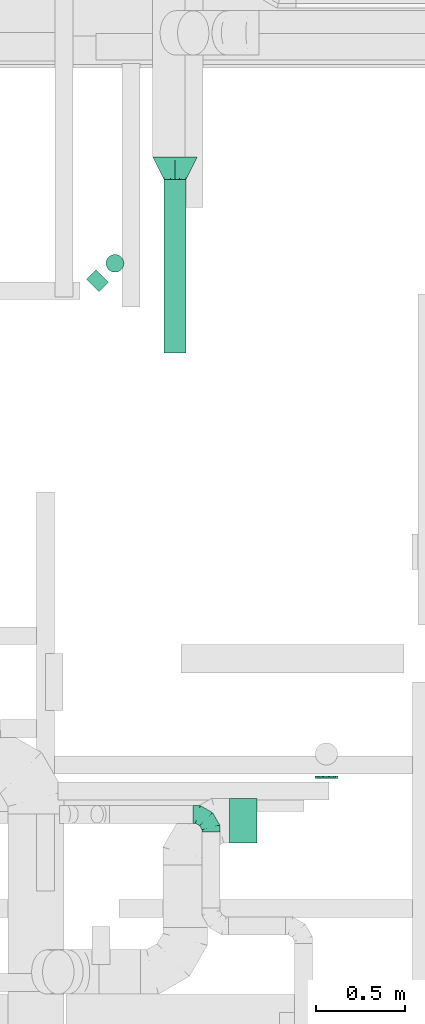
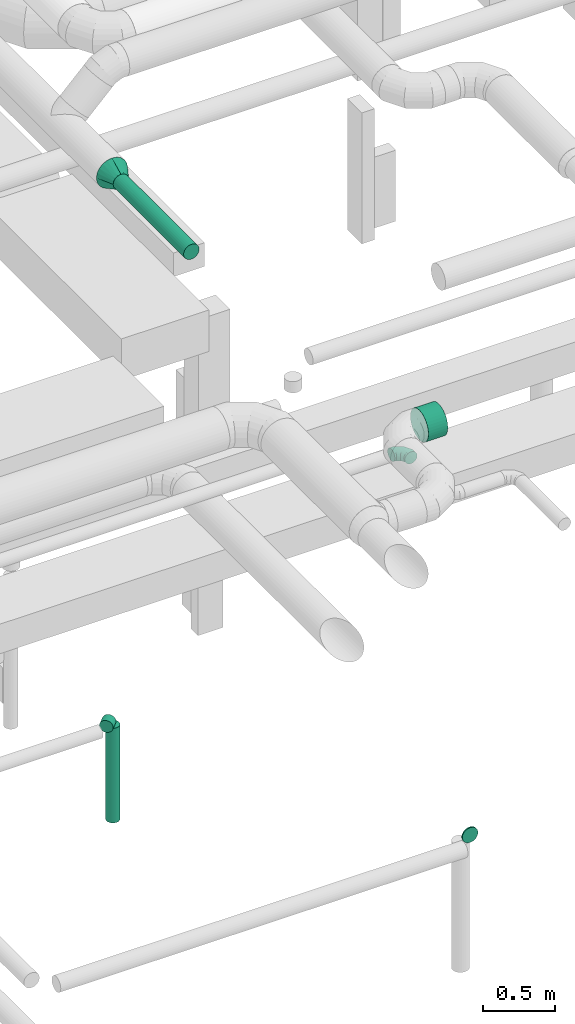
# One storey, part 127 of 337: 5 flow segments, 2 flow fittings.
"""IFC2X3 building model written with IfcOpenShell, lengths in millimetres."""

import ifcopenshell
import ifcopenshell.guid

model = None  # the IFC model being written
_history = None  # IfcOwnerHistory: only IFC2X3 demands one
_inside = {}  # id of a spatial element -> (the spatial element, [elements in it])
_under = {}  # id of a project, library or spatial element -> (it, [spatial elements below it])
_declared = {}  # id of a project -> (the project, [libraries it declares])
_typed = {}  # id of a type object -> (the type object, [elements of that type])
_made_of = {}  # id of a material, layer set ... -> (it, [elements and type objects made of it])


def new_model(schema):
    """Start an empty IFC model of exactly this schema.

    Asked for "IFC4X3", IfcOpenShell would pick the latest addendum, in which some entities
    have other attributes; the version numbers below select the first issue.
    IFC2X3 requires an IfcOwnerHistory on every rooted entity: one is made here for all.
    """
    global model, _history
    if schema == "IFC4X3":
        model = ifcopenshell.file(schema_version=(4, 3, 0, 0))
    else:
        model = ifcopenshell.file(schema=schema)
    _inside.clear()
    _under.clear()
    _declared.clear()
    _typed.clear()
    _made_of.clear()
    _history = None
    if model.schema == "IFC2X3":
        org = make("IfcOrganization", Name="unknown")
        user = make(
            "IfcPersonAndOrganization",
            ThePerson=make("IfcPerson", FamilyName="unknown"),
            TheOrganization=org,
        )
        app = make(
            "IfcApplication",
            ApplicationDeveloper=org,
            Version="unknown",
            ApplicationFullName="unknown",
            ApplicationIdentifier="unknown",
        )
        _history = make(
            "IfcOwnerHistory",
            OwningUser=user,
            OwningApplication=app,
            ChangeAction="ADDED",
            CreationDate=0,
        )
    return model


def make(cls, **values):
    """One entity of the class cls with the attributes given. An attribute that is None is left unset."""
    return model.create_entity(
        cls, **{name: value for name, value in values.items() if value is not None}
    )


def entity(cls, *values):
    """Any entity or typed value of the class cls, its attributes in the order of the schema. None: left unset."""
    e = model.create_entity(cls)
    for i, value in enumerate(values):
        if value is not None:
            e[i] = value
    return e


def rooted(cls, **values):
    """An entity with a GlobalId (a new one), such as an element, a storey or a relation."""
    return make(cls, GlobalId=ifcopenshell.guid.new(), OwnerHistory=_history, **values)


def si_unit(unit_type, name, prefix=None):
    """IfcSIUnit, for example si_unit("LENGTHUNIT", "METRE", prefix="MILLI")."""
    return make("IfcSIUnit", UnitType=unit_type, Prefix=prefix, Name=name)


def converted_unit(unit_type, name, factor, base, dimensions=None, offset=None):
    """IfcConversionBasedUnit, such as the inch: factor (a typed value) times the base unit."""
    return make(
        "IfcConversionBasedUnit"
        if offset is None
        else "IfcConversionBasedUnitWithOffset",
        ConversionOffset=offset,
        Dimensions=None
        if dimensions is None
        else entity("IfcDimensionalExponents", *dimensions),
        UnitType=unit_type,
        Name=name,
        ConversionFactor=make(
            "IfcMeasureWithUnit", ValueComponent=factor, UnitComponent=base
        ),
    )


def derived_unit(unit_type, elements):
    """IfcDerivedUnit: a product of units, each with its exponent."""
    return make(
        "IfcDerivedUnit",
        Elements=[
            make("IfcDerivedUnitElement", Unit=unit, Exponent=power)
            for unit, power in elements
        ],
        UnitType=unit_type,
    )


def assignment(units):
    """IfcUnitAssignment: the units of a project."""
    return None if units is None else make("IfcUnitAssignment", Units=units)


def point(xyz):
    """IfcCartesianPoint."""
    return None if xyz is None else make("IfcCartesianPoint", Coordinates=xyz)


def direction(xyz):
    """IfcDirection."""
    return None if xyz is None else make("IfcDirection", DirectionRatios=xyz)


def frame(location, z_axis=None, x_axis=None):
    """IfcAxis2Placement3D, a coordinate frame: its origin and axes. An axis left out is left unset."""
    return make(
        "IfcAxis2Placement3D",
        Location=point(location),
        Axis=direction(z_axis),
        RefDirection=direction(x_axis),
    )


def frame_2d(location, x_axis=None):
    """IfcAxis2Placement2D, a coordinate frame in the plane: its origin and x axis."""
    return make(
        "IfcAxis2Placement2D", Location=point(location), RefDirection=direction(x_axis)
    )


def origin():
    """The frame at (0, 0, 0) with its axes left unset."""
    return frame((0.0, 0.0, 0.0))


def origin_2d_with_axis():
    """The frame at (0, 0) in the plane with the x axis (1, 0) written out."""
    return frame_2d((0.0, 0.0), x_axis=(1.0, 0.0))


def place(relative_to, where):
    """IfcLocalPlacement: puts the frame where relative to a parent placement (None: the world)."""
    return make(
        "IfcLocalPlacement", PlacementRelTo=relative_to, RelativePlacement=where
    )


def context(
    kind, dimensions, precision=None, world=None, true_north=None, identifier=None
):
    """IfcGeometricRepresentationContext, for example the 3D "Model" context."""
    return make(
        "IfcGeometricRepresentationContext",
        ContextIdentifier=identifier,
        ContextType=kind,
        CoordinateSpaceDimension=dimensions,
        Precision=precision,
        WorldCoordinateSystem=world,
        TrueNorth=true_north,
    )


def subcontext(parent, identifier, kind, view, scale=None):
    """IfcGeometricRepresentationSubContext, for example "Body" below "Model"."""
    return make(
        "IfcGeometricRepresentationSubContext",
        ContextIdentifier=identifier,
        ContextType=kind,
        ParentContext=parent,
        TargetScale=scale,
        TargetView=view,
    )


def project(units=None, contexts=None):
    """IfcProject with its units and contexts."""
    return rooted(
        "IfcProject",
        Name="project",
        RepresentationContexts=contexts,
        UnitsInContext=assignment(units),
    )


def spatial(cls, under=None, at=None, **own):
    """A site, building, storey or space (cls), placed at a placement, below another one or the project."""
    s = rooted(cls, ObjectPlacement=at, **own)
    if under is not None:
        _under.setdefault(under.id(), (under, []))[1].append(s)
    return s


def profile(cls, at=None, kind="AREA", **sizes):
    """A parametric profile (cls). Its sizes go by their IFC names, for example OverallWidth=200.0."""
    return make(cls, ProfileType=kind, Position=at, **sizes)


def circle(**sizes):
    """IfcCircleProfileDef."""
    return profile("IfcCircleProfileDef", **sizes)


def extrude(swept, where, along, depth):
    """IfcExtrudedAreaSolid: the profile swept, set in the frame where, extruded along a direction by depth."""
    return make(
        "IfcExtrudedAreaSolid",
        SweptArea=swept,
        Position=where,
        ExtrudedDirection=direction(along),
        Depth=depth,
    )


def faces_of(points, faces, orient=None, outer=None):
    """IfcFace entities. A face is a list of loops; a loop is a list of indices into points, from 0.

    orient and outer hold one flag for each loop. By default every Orientation is true, the
    first loop of a face is its IfcFaceOuterBound and the others are IfcFaceBound.
    """
    made = []
    for i, loops in enumerate(faces):
        bounds = []
        for j, loop in enumerate(loops):
            is_outer = j == 0 if outer is None else outer[i][j]
            bounds.append(
                make(
                    "IfcFaceOuterBound" if is_outer else "IfcFaceBound",
                    Bound=make("IfcPolyLoop", Polygon=[points[k] for k in loop]),
                    Orientation=True if orient is None else orient[i][j],
                )
            )
        made.append(make("IfcFace", Bounds=bounds))
    return made


def faceted_brep(points, faces, orient=None, outer=None, voids=None):
    """IfcFacetedBrep: a solid bounded by flat faces; with voids (closed shells), ...WithVoids."""
    shared = [point(p) for p in points]
    hull = make("IfcClosedShell", CfsFaces=faces_of(shared, faces, orient, outer))
    if voids is None:
        return make("IfcFacetedBrep", Outer=hull)
    return make(
        "IfcFacetedBrepWithVoids",
        Outer=hull,
        Voids=[
            make(cls, CfsFaces=faces_of(shared, fs, o, b)) for cls, fs, o, b in voids
        ],
    )


def shape(context_of_items, identifier, shape_type, items):
    """IfcShapeRepresentation: the items that make up one representation, for example the "Body"."""
    return make(
        "IfcShapeRepresentation",
        ContextOfItems=context_of_items,
        RepresentationIdentifier=identifier,
        RepresentationType=shape_type,
        Items=items,
    )


def source(mapping_origin, context_of_items, identifier, shape_type, items):
    """IfcRepresentationMap: a shape defined once, which mapped items show again and again."""
    return make(
        "IfcRepresentationMap",
        MappingOrigin=mapping_origin,
        MappedRepresentation=shape(context_of_items, identifier, shape_type, items),
    )


def transform(
    local_origin,
    x_axis=None,
    y_axis=None,
    z_axis=None,
    scale=None,
    scale2=None,
    scale3=None,
    uniform=True,
):
    """IfcCartesianTransformationOperator3D, or its non-uniform kind. x_axis, y_axis, z_axis: its Axis1, 2, 3."""
    if uniform:
        return make(
            "IfcCartesianTransformationOperator3D",
            Axis1=direction(x_axis),
            Axis2=direction(y_axis),
            LocalOrigin=point(local_origin),
            Scale=scale,
            Axis3=direction(z_axis),
        )
    return make(
        "IfcCartesianTransformationOperator3DnonUniform",
        Axis1=direction(x_axis),
        Axis2=direction(y_axis),
        LocalOrigin=point(local_origin),
        Scale=scale,
        Axis3=direction(z_axis),
        Scale2=scale2,
        Scale3=scale3,
    )


def mapped(mapping_source, mapping_target):
    """IfcMappedItem: shows the shape of a source again, moved by a transform."""
    return make(
        "IfcMappedItem", MappingSource=mapping_source, MappingTarget=mapping_target
    )


def material(Name=None, Category=None):
    """IfcMaterial."""
    return make("IfcMaterial", Name=Name, Category=Category)


def made_of(thing, what):
    """Note that an element or type object is made of a material, layer set ...; save() writes the relation."""
    if what is not None:
        _made_of.setdefault(what.id(), (what, []))[1].append(thing)
    return thing


def type_object(cls, material=None, **own):
    """A type object (cls), such as IfcWallType, which elements share."""
    return made_of(rooted(cls, **own), material)


def type_shapes(of_type, sources):
    """Give a type object the sources (RepresentationMaps) that its elements show as mapped items."""
    of_type.RepresentationMaps = sources


def element(
    cls,
    number,
    at=None,
    inside=None,
    cuts=None,
    type_object=None,
    material=None,
    context=None,
    identifier="Body",
    shape_type=None,
    held_by="IfcProductDefinitionShape",
    body=None,
    shapes=None,
    **own,
):
    """One element of the class cls, such as IfcWall. Its Tag is "e" and its number.

    at: its placement. inside: the storey or other place that contains it. cuts: it is an
    opening in that element (IfcRelVoidsElement). A single representation is given by context,
    identifier, shape_type and body (its items); several are given by shapes. held_by: the class
    of the entity that holds the representations. save() writes the other relations.
    """
    e = rooted(cls, Tag="e%d" % number, ObjectPlacement=at, **own)
    if body is not None:
        shapes = [shape(context, identifier, shape_type, body)]
    if shapes is not None:
        e.Representation = make(held_by, Representations=shapes)
    if inside is not None:
        _inside.setdefault(inside.id(), (inside, []))[1].append(e)
    if cuts is not None:
        rooted(
            "IfcRelVoidsElement", RelatingBuildingElement=cuts, RelatedOpeningElement=e
        )
    if type_object is not None:
        _typed.setdefault(type_object.id(), (type_object, []))[1].append(e)
    return made_of(e, material)


def aggregate(whole, parts):
    """IfcRelAggregates: a whole, such as a stair, and the parts it consists of."""
    return rooted("IfcRelAggregates", RelatingObject=whole, RelatedObjects=parts)


def save(model, path):
    """Write the relations noted so far, then the file.

    IfcRelAggregates (storeys below a building ...), IfcRelContainedInSpatialStructure (elements
    in a storey), IfcRelDefinesByType, IfcRelAssociatesMaterial and IfcRelDeclares: one each for
    every whole, place, type object, material and project.
    """
    for whole, parts in _under.values():
        aggregate(whole, parts)
    for where, things in _inside.values():
        rooted(
            "IfcRelContainedInSpatialStructure",
            RelatedElements=things,
            RelatingStructure=where,
        )
    for kind, things in _typed.values():
        rooted("IfcRelDefinesByType", RelatedObjects=things, RelatingType=kind)
    for what, things in _made_of.values():
        rooted("IfcRelAssociatesMaterial", RelatedObjects=things, RelatingMaterial=what)
    for by, libraries in _declared.values():
        rooted("IfcRelDeclares", RelatingContext=by, RelatedDefinitions=libraries)
    model.write(path)


model = new_model("IFC2X3")

# Units and contexts
model_context = context("Model", 3, precision=0.01, world=origin(), true_north=direction((6.12303176911189e-17, 1.0)))
body_context = subcontext(model_context, "Body", "Model", "MODEL_VIEW")
ifc_project = project(units=[si_unit("LENGTHUNIT", "METRE", prefix="MILLI"), si_unit("AREAUNIT", "SQUARE_METRE"), si_unit("VOLUMEUNIT", "CUBIC_METRE"), converted_unit("PLANEANGLEUNIT", "DEGREE", entity("IfcRatioMeasure", 0.0174532925199433), si_unit("PLANEANGLEUNIT", "RADIAN"), dimensions=[0, 0, 0, 0, 0, 0, 0]), si_unit("MASSUNIT", "GRAM", prefix="KILO"), derived_unit("MASSDENSITYUNIT", [(si_unit("MASSUNIT", "GRAM", prefix="KILO"), 1), (si_unit("LENGTHUNIT", "METRE"), -3)]), derived_unit("MOMENTOFINERTIAUNIT", [(si_unit("LENGTHUNIT", "METRE"), 4)]), si_unit("TIMEUNIT", "SECOND"), si_unit("FREQUENCYUNIT", "HERTZ"), si_unit("THERMODYNAMICTEMPERATUREUNIT", "DEGREE_CELSIUS"), derived_unit("THERMALTRANSMITTANCEUNIT", [(si_unit("MASSUNIT", "GRAM", prefix="KILO"), 1), (si_unit("THERMODYNAMICTEMPERATUREUNIT", "KELVIN"), -1), (si_unit("TIMEUNIT", "SECOND"), -3)]), derived_unit("VOLUMETRICFLOWRATEUNIT", [(si_unit("LENGTHUNIT", "METRE"), 3), (si_unit("TIMEUNIT", "SECOND"), -1)]), derived_unit("MASSFLOWRATEUNIT", [(si_unit("MASSUNIT", "GRAM", prefix="KILO"), 1), (si_unit("TIMEUNIT", "SECOND"), -1)]), derived_unit("ROTATIONALFREQUENCYUNIT", [(si_unit("TIMEUNIT", "SECOND"), -1)]), si_unit("ELECTRICCURRENTUNIT", "AMPERE"), si_unit("ELECTRICVOLTAGEUNIT", "VOLT"), si_unit("POWERUNIT", "WATT"), si_unit("FORCEUNIT", "NEWTON", prefix="KILO"), si_unit("ILLUMINANCEUNIT", "LUX"), si_unit("LUMINOUSFLUXUNIT", "LUMEN"), si_unit("LUMINOUSINTENSITYUNIT", "CANDELA"), derived_unit("USERDEFINED", [(si_unit("MASSUNIT", "GRAM", prefix="KILO"), -1), (si_unit("LENGTHUNIT", "METRE"), -2), (si_unit("TIMEUNIT", "SECOND"), 3), (si_unit("LUMINOUSFLUXUNIT", "LUMEN"), 1)]), derived_unit("LINEARVELOCITYUNIT", [(si_unit("LENGTHUNIT", "METRE"), 1), (si_unit("TIMEUNIT", "SECOND"), -1)]), si_unit("PRESSUREUNIT", "PASCAL"), derived_unit("USERDEFINED", [(si_unit("LENGTHUNIT", "METRE"), -2), (si_unit("MASSUNIT", "GRAM", prefix="KILO"), 1), (si_unit("TIMEUNIT", "SECOND"), -2)]), derived_unit("LINEARFORCEUNIT", [(si_unit("MASSUNIT", "GRAM", prefix="KILO"), 1), (si_unit("LENGTHUNIT", "METRE"), 1), (si_unit("TIMEUNIT", "SECOND"), -2), (si_unit("LENGTHUNIT", "METRE"), -1)]), derived_unit("PLANARFORCEUNIT", [(si_unit("MASSUNIT", "GRAM", prefix="KILO"), 1), (si_unit("LENGTHUNIT", "METRE"), 1), (si_unit("TIMEUNIT", "SECOND"), -2), (si_unit("LENGTHUNIT", "METRE"), -2)])], contexts=[model_context])

# Site, building, storey
site_placement = place(None, origin())
site = spatial("IfcSite", under=ifc_project, at=site_placement, CompositionType="ELEMENT")
building_placement = place(site_placement, origin())
building = spatial("IfcBuilding", under=site, at=building_placement, CompositionType="ELEMENT")
storey_placement = place(building_placement, origin())
storey = spatial("IfcBuildingStorey", under=building, at=storey_placement, CompositionType="ELEMENT", Elevation=0.0)

# Flow segments
duct_segment_type = type_object("IfcDuctSegmentType", PredefinedType="NOTDEFINED")
flow_segment_1_placement = place(storey_placement, frame((37100.2, 4113.76, -664.1)))
element("IfcFlowSegment", 1, at=flow_segment_1_placement, inside=storey, type_object=duct_segment_type, context=body_context, shape_type="SweptSolid", body=[
    extrude(circle(Radius=62.5, at=origin_2d_with_axis()), frame((64.1, 0.0, 64.1), z_axis=(0.0, 1.0, 0.0), x_axis=(1.0, 0.0, 0.0)), (0.0, 0.0, 1.0), 9.92661999999447),
])
flow_segment_2_placement = place(storey_placement, frame((35815.06, 6841.85, -951.6)))
element("IfcFlowSegment", 2, at=flow_segment_2_placement, inside=storey, type_object=duct_segment_type, context=body_context, shape_type="SweptSolid", body=[
    extrude(circle(Radius=50.0, at=origin_2d_with_axis()), frame((36.95, 36.95, 51.6), z_axis=(0.707106781186548, 0.707106781186548, 0.0), x_axis=(0.707106781186548, -0.707106781186548, 0.0)), (0.0, 0.0, 1.0), 76.2779207257766),
])
flow_segment_3_placement = place(storey_placement, frame((35925.07, 6951.85, -1800.0)))
element("IfcFlowSegment", 3, at=flow_segment_3_placement, inside=storey, type_object=duct_segment_type, context=body_context, shape_type="SweptSolid", body=[
    extrude(circle(Radius=50.0, at=origin_2d_with_axis()), frame((51.6, 51.6, 0.0), z_axis=(0.0, 0.0, 1.0), x_axis=(-0.707106781186549, -0.707106781186546, 0.0)), (0.0, 0.0, 1.0), 800.000000000009),
])
flow_segment_4_placement = place(storey_placement, frame((36620.66, 3748.01, 3073.4)))
element("IfcFlowSegment", 4, at=flow_segment_4_placement, inside=storey, type_object=duct_segment_type, context=body_context, shape_type="SweptSolid", body=[
    extrude(circle(Radius=125.0, at=origin_2d_with_axis()), frame((0.0, 126.6, 126.6), z_axis=(1.0, 0.0, 0.0), x_axis=(0.0, -1.0, 0.0)), (0.0, 0.0, 1.0), 154.999999999999),
])
flow_segment_5_placement = place(storey_placement, frame((36249.81, 6500.0, 3115.9)))
element("IfcFlowSegment", 5, at=flow_segment_5_placement, inside=storey, type_object=duct_segment_type, context=body_context, shape_type="SweptSolid", body=[
    extrude(circle(Radius=62.5, at=origin_2d_with_axis()), frame((64.1, 0.0, 64.1), z_axis=(0.0, 1.0, 0.0), x_axis=(-1.0, 0.0, 0.0)), (0.0, 0.0, 1.0), 974.999999999985),
])

# Flow fittings
ifc_material = material()
duct_fitting_type_1 = type_object("IfcDuctFittingType", PredefinedType="NOTDEFINED", material=ifc_material)
shared_shape_1 = source(origin(), body_context, "Body", "Brep", [
    faceted_brep([(-100.0, 0.0, -50.0), (-100.0, -12.94, -48.3), (-100.0, -25.0, -43.3), (-100.0, -35.36, -35.36), (-100.0, -43.3, -25.0), (-100.0, -48.3, -12.94), (-100.0, -50.0, 0.0), (-100.0, -48.3, 12.94), (-100.0, -43.3, 25.0), (-100.0, -35.36, 35.36), (-100.0, -25.0, 43.3), (-100.0, -12.94, 48.3), (-100.0, 0.0, 50.0), (-100.0, 12.94, 48.3), (-100.0, 25.0, 43.3), (-100.0, 35.36, 35.36), (-100.0, 43.3, 25.0), (-100.0, 48.3, 12.94), (-100.0, 50.0, 0.0), (-100.0, 48.3, -12.94), (-100.0, 43.3, -25.0), (-100.0, 35.36, -35.36), (-100.0, 25.0, -43.3), (-100.0, 12.94, -48.3), (-76.67, 12.94, 48.3), (-79.9, 25.0, 43.3), (-73.21, 0.0, 50.0), (-82.68, 35.36, 35.36), (-86.15, 48.3, 12.94), (-86.6, 50.0, 0.0), (-84.81, 43.3, 25.0), (-84.81, 43.3, -25.0), (-82.68, 35.36, -35.36), (-86.15, 48.3, -12.94), (-76.67, 12.94, -48.3), (-73.21, 0.0, -50.0), (-79.9, 25.0, -43.3), (-69.74, -12.94, -48.3), (-66.51, -25.0, -43.3), (-63.73, -35.36, -35.36), (-61.6, -43.3, -25.0), (-60.26, -48.3, -12.94), (-59.81, -50.0, 0.0), (-60.26, -48.3, 12.94), (-61.6, -43.3, 25.0), (-63.73, -35.36, 35.36), (-66.51, -25.0, 43.3), (-69.74, -12.94, 48.3), (-36.27, 36.27, 48.3), (-45.1, 45.1, 43.3), (-26.79, 26.79, 50.0), (-52.68, 52.68, 35.36), (-58.49, 58.49, 25.0), (-62.15, 62.15, 12.94), (-63.4, 63.4, 0.0), (-62.15, 62.15, -12.94), (-58.49, 58.49, -25.0), (-52.68, 52.68, -35.36), (-36.27, 36.27, -48.3), (-26.79, 26.79, -50.0), (-45.1, 45.1, -43.3), (-17.32, 17.32, -48.3), (-8.49, 8.49, -43.3), (-0.91, 0.91, -35.36), (4.9, -4.9, -25.0), (8.56, -8.56, -12.94), (9.81, -9.81, 0.0), (8.56, -8.56, 12.94), (4.9, -4.9, 25.0), (-0.91, 0.91, 35.36), (-8.49, 8.49, 43.3), (-17.32, 17.32, 48.3), (-12.94, 76.67, 48.3), (-25.0, 79.9, 43.3), (0.0, 73.21, 50.0), (-35.36, 82.68, 35.36), (-43.3, 84.81, 25.0), (-48.3, 86.15, 12.94), (-50.0, 86.6, 0.0), (-48.3, 86.15, -12.94), (-43.3, 84.81, -25.0), (-35.36, 82.68, -35.36), (-12.94, 76.67, -48.3), (0.0, 73.21, -50.0), (-25.0, 79.9, -43.3), (12.94, 69.74, -48.3), (25.0, 66.51, -43.3), (35.36, 63.73, -35.36), (43.3, 61.6, -25.0), (48.3, 60.26, -12.94), (50.0, 59.81, 0.0), (48.3, 60.26, 12.94), (43.3, 61.6, 25.0), (35.36, 63.73, 35.36), (25.0, 66.51, 43.3), (12.94, 69.74, 48.3), (-12.94, 100.0, -48.3), (-25.0, 100.0, -43.3), (-35.36, 100.0, -35.36), (-43.3, 100.0, -25.0), (-48.3, 100.0, -12.94), (-50.0, 100.0, 0.0), (-48.3, 100.0, 12.94), (-43.3, 100.0, 25.0), (-35.36, 100.0, 35.36), (-25.0, 100.0, 43.3), (-12.94, 100.0, 48.3), (0.0, 100.0, 50.0), (12.94, 100.0, 48.3), (25.0, 100.0, 43.3), (35.36, 100.0, 35.36), (43.3, 100.0, 25.0), (48.3, 100.0, 12.94), (50.0, 100.0, 0.0), (48.3, 100.0, -12.94), (43.3, 100.0, -25.0), (35.36, 100.0, -35.36), (25.0, 100.0, -43.3), (12.94, 100.0, -48.3), (0.0, 100.0, -50.0)], [[[0, 1, 2, 3, 4, 5, 6, 7, 8, 9, 10, 11, 12, 13, 14, 15, 16, 17, 18, 19, 20, 21, 22, 23]], [[24, 25, 14, 13]], [[26, 24, 13, 12]], [[14, 25, 27, 15]], [[28, 29, 18, 17]], [[30, 28, 17, 16]], [[15, 27, 30, 16]], [[20, 31, 32, 21]], [[33, 31, 20, 19]], [[18, 29, 33, 19]], [[34, 35, 0, 23]], [[36, 34, 23, 22]], [[32, 36, 22, 21]], [[2, 1, 37, 38]], [[3, 2, 38, 39]], [[0, 35, 37, 1]], [[5, 4, 40, 41]], [[6, 5, 41, 42]], [[3, 39, 40, 4]], [[6, 42, 43, 7]], [[7, 43, 44, 8]], [[8, 44, 45, 9]], [[10, 46, 47, 11]], [[11, 47, 26, 12]], [[10, 9, 45, 46]], [[48, 49, 25, 24]], [[50, 48, 24, 26]], [[27, 25, 49, 51]], [[52, 53, 28, 30]], [[51, 52, 30, 27]], [[29, 28, 53, 54]], [[55, 56, 31, 33]], [[54, 55, 33, 29]], [[57, 32, 31, 56]], [[58, 59, 35, 34]], [[60, 58, 34, 36]], [[57, 60, 36, 32]], [[37, 35, 59, 61]], [[38, 37, 61, 62]], [[39, 38, 62, 63]], [[41, 40, 64, 65]], [[42, 41, 65, 66]], [[63, 64, 40, 39]], [[43, 42, 66, 67]], [[44, 43, 67, 68]], [[68, 69, 45, 44]], [[46, 45, 69, 70]], [[47, 46, 70, 71]], [[26, 47, 71, 50]], [[72, 73, 49, 48]], [[74, 72, 48, 50]], [[51, 49, 73, 75]], [[76, 77, 53, 52]], [[75, 76, 52, 51]], [[54, 53, 77, 78]], [[79, 80, 56, 55]], [[78, 79, 55, 54]], [[81, 57, 56, 80]], [[82, 83, 59, 58]], [[84, 82, 58, 60]], [[81, 84, 60, 57]], [[61, 59, 83, 85]], [[62, 61, 85, 86]], [[63, 62, 86, 87]], [[65, 64, 88, 89]], [[66, 65, 89, 90]], [[87, 88, 64, 63]], [[67, 66, 90, 91]], [[68, 67, 91, 92]], [[92, 93, 69, 68]], [[70, 69, 93, 94]], [[71, 70, 94, 95]], [[50, 71, 95, 74]], [[96, 97, 98, 99, 100, 101, 102, 103, 104, 105, 106, 107, 108, 109, 110, 111, 112, 113, 114, 115, 116, 117, 118, 119]], [[72, 74, 107, 106]], [[73, 72, 106, 105]], [[75, 73, 105, 104]], [[77, 76, 103, 102]], [[78, 77, 102, 101]], [[75, 104, 103, 76]], [[78, 101, 100, 79]], [[79, 100, 99, 80]], [[80, 99, 98, 81]], [[96, 119, 83, 82]], [[97, 96, 82, 84]], [[84, 81, 98, 97]], [[83, 119, 118, 85]], [[85, 118, 117, 86]], [[86, 117, 116, 87]], [[88, 115, 114, 89]], [[89, 114, 113, 90]], [[87, 116, 115, 88]], [[91, 90, 113, 112]], [[92, 91, 112, 111]], [[93, 92, 111, 110]], [[95, 94, 109, 108]], [[74, 95, 108, 107]], [[110, 109, 94, 93]]]),
])
type_shapes(duct_fitting_type_1, [shared_shape_1])
flow_fitting_1_placement = place(storey_placement, frame((36515.48, 3909.56, 3000.0), z_axis=(0.0, 0.0, 1.0), x_axis=(0.0, 1.0, 0.0)))
element("IfcFlowFitting", 6, at=flow_fitting_1_placement, inside=storey, type_object=duct_fitting_type_1, material=ifc_material, context=body_context, shape_type="MappedRepresentation", body=[
    mapped(shared_shape_1, transform((0.0, 0.0, 0.0), scale=1.0)),
])
duct_fitting_type_2 = type_object("IfcDuctFittingType", PredefinedType="NOTDEFINED", material=ifc_material)
shared_shape_2 = source(origin(), body_context, "Body", "Brep", [
    faceted_brep([(125.0, -57.74, 23.92), (125.0, -60.12, 11.96), (125.0, -62.5, 0.0), (125.0, -60.12, -11.96), (125.0, -57.74, -23.92), (125.0, -50.97, -34.06), (125.0, -44.19, -44.19), (125.0, -34.06, -50.97), (125.0, -23.92, -57.74), (125.0, -11.96, -60.12), (125.0, 0.0, -62.5), (125.0, 11.96, -60.12), (125.0, 23.92, -57.74), (125.0, 34.06, -50.97), (125.0, 44.19, -44.19), (125.0, 50.97, -34.06), (125.0, 57.74, -23.92), (125.0, 60.12, -11.96), (125.0, 62.5, 0.0), (125.0, 60.12, 11.96), (125.0, 57.74, 23.92), (125.0, 50.97, 34.06), (125.0, 44.19, 44.19), (125.0, 34.06, 50.97), (125.0, 23.92, 57.74), (125.0, 11.96, 60.12), (125.0, 0.0, 62.5), (125.0, -11.96, 60.12), (125.0, -23.92, 57.74), (125.0, -34.06, 50.97), (125.0, -44.19, 44.19), (125.0, -50.97, 34.06), (0.0, -125.0, 0.0), (0.0, -118.88, 38.63), (0.0, -101.13, 73.47), (0.0, -73.47, 101.13), (0.0, -38.63, 118.88), (0.0, 0.0, 125.0), (0.0, 38.63, 118.88), (0.0, 73.47, 101.13), (0.0, 101.13, 73.47), (0.0, 118.88, 38.63), (0.0, 125.0, 0.0), (0.0, 118.88, -38.63), (0.0, 101.13, -73.47), (0.0, 73.47, -101.13), (0.0, 38.63, -118.88), (0.0, 0.0, -125.0), (0.0, -38.63, -118.88), (0.0, -73.47, -101.13), (0.0, -101.13, -73.47), (0.0, -118.88, -38.63)], [[[0, 1, 2, 3, 4, 5, 6, 7, 8, 9, 10, 11, 12, 13, 14, 15, 16, 17, 18, 19, 20, 21, 22, 23, 24, 25, 26, 27, 28, 29, 30, 31]], [[32, 33, 34, 35, 36, 37, 38, 39, 40, 41, 42, 43, 44, 45, 46, 47, 48, 49, 50, 51]], [[37, 25, 38]], [[24, 39, 38]], [[40, 22, 21, 20]], [[41, 20, 19]], [[39, 24, 23, 22]], [[18, 42, 19]], [[25, 37, 26]], [[40, 20, 41]], [[19, 42, 41]], [[25, 24, 38]], [[22, 40, 39]], [[32, 1, 33]], [[0, 34, 33]], [[35, 30, 29, 28]], [[36, 28, 27]], [[34, 0, 31, 30]], [[26, 37, 27]], [[1, 32, 2]], [[35, 28, 36]], [[27, 37, 36]], [[1, 0, 33]], [[30, 35, 34]], [[47, 9, 48]], [[8, 49, 48]], [[50, 6, 5, 4]], [[51, 4, 3]], [[49, 8, 7, 6]], [[2, 32, 3]], [[9, 47, 10]], [[50, 4, 51]], [[3, 32, 51]], [[9, 8, 48]], [[6, 50, 49]], [[42, 17, 43]], [[16, 44, 43]], [[45, 14, 13, 12]], [[46, 12, 11]], [[44, 16, 15, 14]], [[10, 47, 11]], [[17, 42, 18]], [[45, 12, 46]], [[11, 47, 46]], [[17, 16, 43]], [[14, 45, 44]]]),
])
type_shapes(duct_fitting_type_2, [shared_shape_2])
flow_fitting_2_placement = place(storey_placement, frame((36313.9, 7600.0, 3180.0), z_axis=(0.0, 0.0, 1.0), x_axis=(0.0, -1.0, 0.0)))
element("IfcFlowFitting", 7, at=flow_fitting_2_placement, inside=storey, type_object=duct_fitting_type_2, material=ifc_material, context=body_context, shape_type="MappedRepresentation", body=[
    mapped(shared_shape_2, transform((0.0, 0.0, 0.0), scale=1.0)),
])

save(model, "model.ifc")
